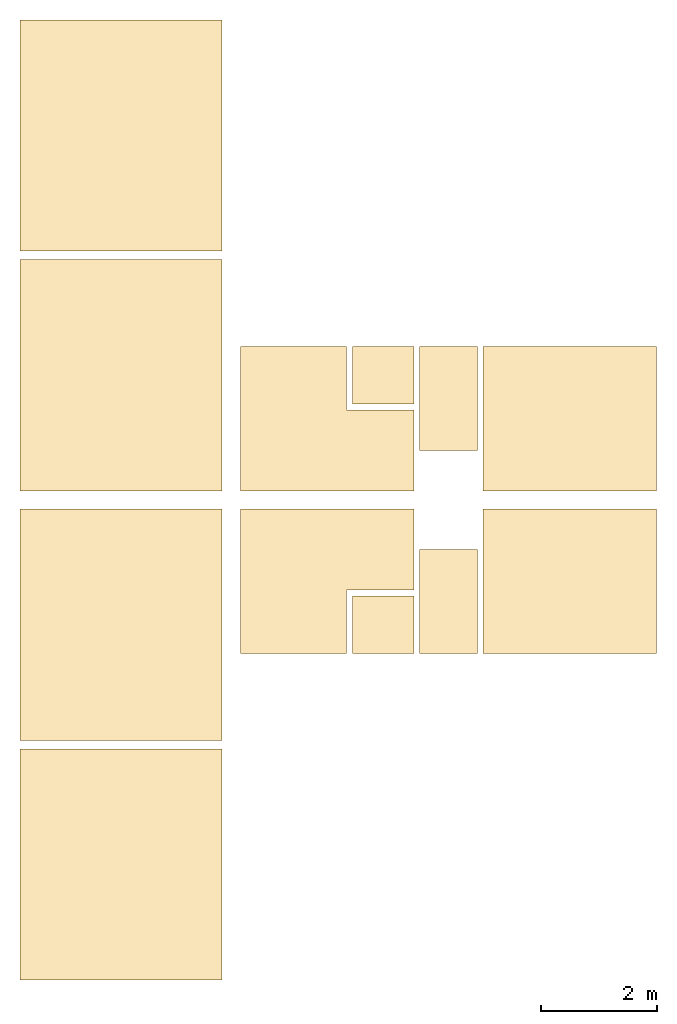
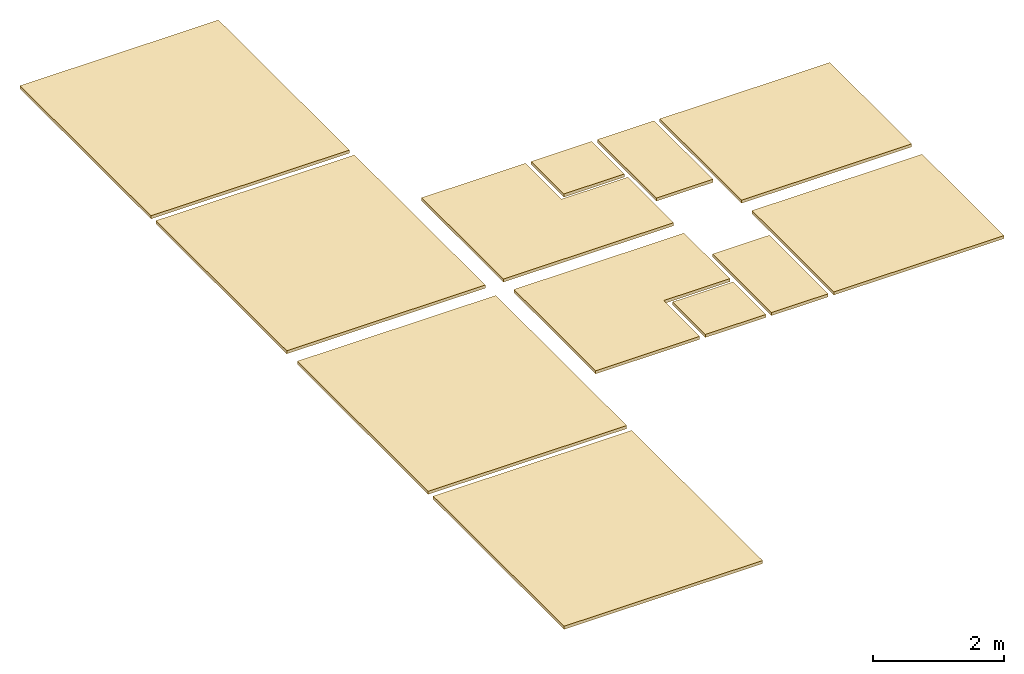
# One storey: 10 coverings.
"""IFC2X3 building model written with IfcOpenShell, lengths in millimetres."""

from ifc_helpers import new_model, entity, si_unit, converted_unit, derived_unit, direction, frame, frame_2d, origin, origin_2d_with_axis, place, context, subcontext, project, spatial, polyline, rectangle, outline, extrude, material, layer, layer_set, layer_usage, type_object, element, save


model = new_model("IFC2X3")

# Units and contexts
model_context = context("Model", 3, precision=0.01, world=origin(), true_north=direction((6.12303176911189e-17, 1.0)))
body_context = subcontext(model_context, "Body", "Model", "MODEL_VIEW")
ifc_project = project(units=[si_unit("LENGTHUNIT", "METRE", prefix="MILLI"), si_unit("AREAUNIT", "SQUARE_METRE"), si_unit("VOLUMEUNIT", "CUBIC_METRE"), converted_unit("PLANEANGLEUNIT", "DEGREE", entity("IfcRatioMeasure", 0.0174532925199433), si_unit("PLANEANGLEUNIT", "RADIAN"), dimensions=[0, 0, 0, 0, 0, 0, 0]), si_unit("MASSUNIT", "GRAM", prefix="KILO"), derived_unit("MASSDENSITYUNIT", [(si_unit("MASSUNIT", "GRAM", prefix="KILO"), 1), (si_unit("LENGTHUNIT", "METRE"), -3)]), si_unit("TIMEUNIT", "SECOND"), si_unit("FREQUENCYUNIT", "HERTZ"), si_unit("THERMODYNAMICTEMPERATUREUNIT", "DEGREE_CELSIUS"), derived_unit("THERMALTRANSMITTANCEUNIT", [(si_unit("MASSUNIT", "GRAM", prefix="KILO"), 1), (si_unit("THERMODYNAMICTEMPERATUREUNIT", "KELVIN"), -1), (si_unit("TIMEUNIT", "SECOND"), -3)]), derived_unit("VOLUMETRICFLOWRATEUNIT", [(si_unit("LENGTHUNIT", "METRE"), 3), (si_unit("TIMEUNIT", "SECOND"), -1)]), si_unit("ELECTRICCURRENTUNIT", "AMPERE"), si_unit("ELECTRICVOLTAGEUNIT", "VOLT"), si_unit("POWERUNIT", "WATT"), si_unit("FORCEUNIT", "NEWTON", prefix="KILO"), si_unit("ILLUMINANCEUNIT", "LUX"), si_unit("LUMINOUSFLUXUNIT", "LUMEN"), si_unit("LUMINOUSINTENSITYUNIT", "CANDELA"), derived_unit("USERDEFINED", [(si_unit("MASSUNIT", "GRAM", prefix="KILO"), -1), (si_unit("LENGTHUNIT", "METRE"), -2), (si_unit("TIMEUNIT", "SECOND"), 3), (si_unit("LUMINOUSFLUXUNIT", "LUMEN"), 1)]), derived_unit("LINEARVELOCITYUNIT", [(si_unit("LENGTHUNIT", "METRE"), 1), (si_unit("TIMEUNIT", "SECOND"), -1)]), si_unit("PRESSUREUNIT", "PASCAL"), derived_unit("USERDEFINED", [(si_unit("LENGTHUNIT", "METRE"), -2), (si_unit("MASSUNIT", "GRAM", prefix="KILO"), 1), (si_unit("TIMEUNIT", "SECOND"), -2)])], contexts=[model_context])

# Site, building, storey
site_placement = place(None, origin())
site = spatial("IfcSite", under=ifc_project, at=site_placement, CompositionType="ELEMENT")
building_placement = place(site_placement, origin())
building = spatial("IfcBuilding", under=site, at=building_placement, CompositionType="ELEMENT")
storey_placement = place(building_placement, frame((0.0, 0.0, 4000.0)))
storey = spatial("IfcBuildingStorey", under=building, at=storey_placement, Name="01 Level", CompositionType="ELEMENT", Elevation=4000.0)

# Coverings
ifc_material_1 = material(Name="02_Metal Stud Layer")
ifc_layer_1 = layer(ifc_material_1, 45.0)
ifc_material_2 = material(Name="05_fa")
ifc_layer_2 = layer(ifc_material_2, 12.0)
ifc_layer_set_1 = layer_set([ifc_layer_1, ifc_layer_2], Name="Compound Ceiling:1")
ifc_layer_usage_1 = layer_usage(ifc_layer_set_1, "AXIS3", "POSITIVE", 0.0)
covering_type_1 = type_object("IfcCoveringType", Name="Compound Ceiling:1", PredefinedType="CEILING")
covering_1_placement = place(storey_placement, frame((25503.4900708518, -71491.2395851399, 2600.0)))
element("IfcCovering", 1, at=covering_1_placement, inside=storey, type_object=covering_type_1, material=ifc_layer_usage_1, Name="Compound Ceiling:1", ObjectType="Compound Ceiling:1", PredefinedType="CEILING", context=body_context, shape_type="SweptSolid", body=[
    extrude(rectangle(XDim=2999.99999999999, YDim=2499.99999999999, at=frame_2d((0.0, 4.32009983342141e-12), x_axis=(1.0, 0.0))), frame((1500.0, 1250.0, 0.0), z_axis=(0.0, 0.0, 1.0), x_axis=(-1.0, 0.0, 0.0)), (0.0, 0.0, 1.0), 57.0),
])
ifc_layer_3 = layer(ifc_material_1, 45.0)
ifc_material_3 = material(Name="03")
ifc_layer_4 = layer(ifc_material_3, 12.0)
ifc_layer_set_2 = layer_set([ifc_layer_3, ifc_layer_4], Name="Compound Ceiling:2")
ifc_layer_usage_2 = layer_usage(ifc_layer_set_2, "AXIS3", "POSITIVE", 0.0)
covering_type_2 = type_object("IfcCoveringType", Name="Compound Ceiling:2", PredefinedType="CEILING")
covering_2_placement = place(storey_placement, frame((24403.4900708518, -71491.2395851399, 2600.0)))
element("IfcCovering", 2, at=covering_2_placement, inside=storey, type_object=covering_type_2, material=ifc_layer_usage_2, Name="Compound Ceiling:2", ObjectType="Compound Ceiling:2", PredefinedType="CEILING", context=body_context, shape_type="SweptSolid", body=[
    extrude(rectangle(XDim=999.999999999998, YDim=1799.99999999999, at=frame_2d((2.1600499167107e-12, -8.64019966684282e-12), x_axis=(1.0, 0.0))), frame((500.0, 900.0, 0.0), z_axis=(0.0, 0.0, 1.0), x_axis=(-1.0, 0.0, 0.0)), (0.0, 0.0, 1.0), 57.0),
])
ifc_layer_usage_3 = layer_usage(ifc_layer_set_2, "AXIS3", "POSITIVE", 0.0)
covering_type_3 = type_object("IfcCoveringType", Name="Compound Ceiling:2", PredefinedType="CEILING")
covering_3_placement = place(storey_placement, frame((21303.4900708518, -71491.2395851399, 2600.0)))
element("IfcCovering", 3, at=covering_3_placement, inside=storey, type_object=covering_type_3, material=ifc_layer_usage_3, Name="Compound Ceiling:2", ObjectType="Compound Ceiling:2", PredefinedType="CEILING", context=body_context, shape_type="SweptSolid", body=[
    extrude(outline(polyline([(-1200.0, 221.666666666673), (-1200.0, -1610.83333333334), (1300.0, -1610.83333333333), (1300.0, 1389.16666666667), (-100.0, 1389.16666666667), (-100.0, 221.666666666673), (-1200.0, 221.666666666673)])), frame((1610.83333333334, 1200.0, 0.0), z_axis=(0.0, 0.0, -1.0), x_axis=(0.0, 1.0, 0.0)), (0.0, 0.0, -1.0), 57.0),
    extrude(rectangle(XDim=1067.5, YDim=999.999999999989, at=frame_2d((-2.1600499167107e-12, -8.66862137627322e-12), x_axis=(1.0, 0.0))), frame((2466.25000000001, 500.0, 0.0), z_axis=(0.0, 0.0, 1.0), x_axis=(-1.0, 0.0, 0.0)), (0.0, 0.0, 1.0), 57.0),
])
ifc_layer_5 = layer(ifc_material_1, 45.0)
ifc_material_4 = material(Name="03")
ifc_layer_6 = layer(ifc_material_4, 12.0)
ifc_layer_set_3 = layer_set([ifc_layer_5, ifc_layer_6], Name="Compound Ceiling:3")
ifc_layer_usage_4 = layer_usage(ifc_layer_set_3, "AXIS3", "POSITIVE", 0.0)
covering_type_4 = type_object("IfcCoveringType", Name="Compound Ceiling:3", PredefinedType="CEILING")
covering_4_placement = place(storey_placement, frame((17483.4900708518, -72991.2395851399, 2600.0)))
element("IfcCovering", 4, at=covering_4_placement, inside=storey, type_object=covering_type_4, material=ifc_layer_usage_4, Name="Compound Ceiling:3", ObjectType="Compound Ceiling:3", PredefinedType="CEILING", context=body_context, shape_type="SweptSolid", body=[
    extrude(rectangle(XDim=4000.0, YDim=3500.00000000002, at=frame_2d((0.0, 3.29691829392686e-12), x_axis=(1.0, 0.0))), frame((1750.0, 2000.0, 0.0), z_axis=(0.0, 0.0, 1.0), x_axis=(0.0, 1.0, 0.0)), (0.0, 0.0, 1.0), 57.0),
])
ifc_layer_usage_5 = layer_usage(ifc_layer_set_3, "AXIS3", "POSITIVE", 0.0)
covering_type_5 = type_object("IfcCoveringType", Name="Compound Ceiling:3", PredefinedType="CEILING")
covering_5_placement = place(storey_placement, frame((17483.4900708518, -77141.2395851399, 2600.0)))
element("IfcCovering", 5, at=covering_5_placement, inside=storey, type_object=covering_type_5, material=ifc_layer_usage_5, Name="Compound Ceiling:3", ObjectType="Compound Ceiling:3", PredefinedType="CEILING", context=body_context, shape_type="SweptSolid", body=[
    extrude(rectangle(XDim=3999.99999999999, YDim=3500.00000000002, at=frame_2d((144.000000000009, 350.000000000003), x_axis=(1.0, 0.0))), frame((2100.0, 1856.0, 0.0), z_axis=(0.0, 0.0, 1.0), x_axis=(0.0, 1.0, 0.0)), (0.0, 0.0, 1.0), 57.0),
])
ifc_layer_usage_6 = layer_usage(ifc_layer_set_1, "AXIS3", "POSITIVE", 0.0)
covering_type_6 = type_object("IfcCoveringType", Name="Compound Ceiling:1", PredefinedType="CEILING")
covering_6_placement = place(storey_placement, frame((25503.4900708518, -68671.2395851399, 2600.0)))
element("IfcCovering", 6, at=covering_6_placement, inside=storey, type_object=covering_type_6, material=ifc_layer_usage_6, Name="Compound Ceiling:1", ObjectType="Compound Ceiling:1", PredefinedType="CEILING", context=body_context, shape_type="SweptSolid", body=[
    extrude(rectangle(XDim=2500.0, YDim=2999.99999999999, at=frame_2d((0.0, -4.32009983342141e-12), x_axis=(1.0, 0.0))), frame((1500.0, 1250.0, 0.0), z_axis=(0.0, 0.0, 1.0), x_axis=(0.0, 1.0, 0.0)), (0.0, 0.0, 1.0), 57.0),
])
ifc_layer_usage_7 = layer_usage(ifc_layer_set_2, "AXIS3", "POSITIVE", 0.0)
covering_type_7 = type_object("IfcCoveringType", Name="Compound Ceiling:2", PredefinedType="CEILING")
covering_7_placement = place(storey_placement, frame((24403.4900708518, -67971.2395851399, 2600.0)))
element("IfcCovering", 7, at=covering_7_placement, inside=storey, type_object=covering_type_7, material=ifc_layer_usage_7, Name="Compound Ceiling:2", ObjectType="Compound Ceiling:2", PredefinedType="CEILING", context=body_context, shape_type="SweptSolid", body=[
    extrude(rectangle(XDim=1800.00000000001, YDim=999.999999999998, at=origin_2d_with_axis()), frame((500.0, 900.0, 0.0), z_axis=(0.0, 0.0, 1.0), x_axis=(0.0, 1.0, 0.0)), (0.0, 0.0, 1.0), 57.0),
])
ifc_layer_usage_8 = layer_usage(ifc_layer_set_2, "AXIS3", "POSITIVE", 0.0)
covering_type_8 = type_object("IfcCoveringType", Name="Compound Ceiling:2", PredefinedType="CEILING")
covering_8_placement = place(storey_placement, frame((21303.4900708518, -68671.2395851399, 2600.0)))
element("IfcCovering", 8, at=covering_8_placement, inside=storey, type_object=covering_type_8, material=ifc_layer_usage_8, Name="Compound Ceiling:2", ObjectType="Compound Ceiling:2", PredefinedType="CEILING", context=body_context, shape_type="SweptSolid", body=[
    extrude(rectangle(XDim=999.999999999998, YDim=1067.5, at=origin_2d_with_axis()), frame((2466.25000000002, 2000.0, 0.0), z_axis=(0.0, 0.0, 1.0), x_axis=(0.0, 1.0, 0.0)), (0.0, 0.0, 1.0), 57.0),
    extrude(outline(polyline([(-221.666666666677, -1200.0), (1610.83333333333, -1200.0), (1610.83333333334, 1300.0), (-1389.16666666666, 1300.0), (-1389.16666666667, -100.0), (-221.666666666673, -100.0), (-221.666666666677, -1200.0)])), frame((1610.83333333334, 1300.0, 0.0), z_axis=(0.0, 0.0, 1.0), x_axis=(-1.0, 0.0, 0.0)), (0.0, 0.0, 1.0), 57.0),
])
ifc_layer_usage_9 = layer_usage(ifc_layer_set_3, "AXIS3", "POSITIVE", 0.0)
covering_type_9 = type_object("IfcCoveringType", Name="Compound Ceiling:3", PredefinedType="CEILING")
covering_9_placement = place(storey_placement, frame((17483.4900708518, -68671.2395851399, 2600.0)))
element("IfcCovering", 9, at=covering_9_placement, inside=storey, type_object=covering_type_9, material=ifc_layer_usage_9, Name="Compound Ceiling:3", ObjectType="Compound Ceiling:3", PredefinedType="CEILING", context=body_context, shape_type="SweptSolid", body=[
    extrude(rectangle(XDim=3500.00000000002, YDim=4000.0, at=origin_2d_with_axis()), frame((1750.0, 2000.0, 0.0), z_axis=(0.0, 0.0, 1.0), x_axis=(-1.0, 0.0, 0.0)), (0.0, 0.0, 1.0), 57.0),
])
ifc_layer_usage_10 = layer_usage(ifc_layer_set_3, "AXIS3", "POSITIVE", 0.0)
covering_type_10 = type_object("IfcCoveringType", Name="Compound Ceiling:3", PredefinedType="CEILING")
covering_10_placement = place(storey_placement, frame((17483.4900708518, -64521.2395851399, 2600.0)))
element("IfcCovering", 10, at=covering_10_placement, inside=storey, type_object=covering_type_10, material=ifc_layer_usage_10, Name="Compound Ceiling:3", ObjectType="Compound Ceiling:3", PredefinedType="CEILING", context=body_context, shape_type="SweptSolid", body=[
    extrude(rectangle(XDim=4000.0, YDim=3500.00000000002, at=frame_2d((-143.999999999987, 350.000000000001), x_axis=(1.0, 0.0))), frame((2100.0, 2144.0, 0.0), z_axis=(0.0, 0.0, 1.0), x_axis=(0.0, 1.0, 0.0)), (0.0, 0.0, 1.0), 57.0),
])

save(model, "model.ifc")
